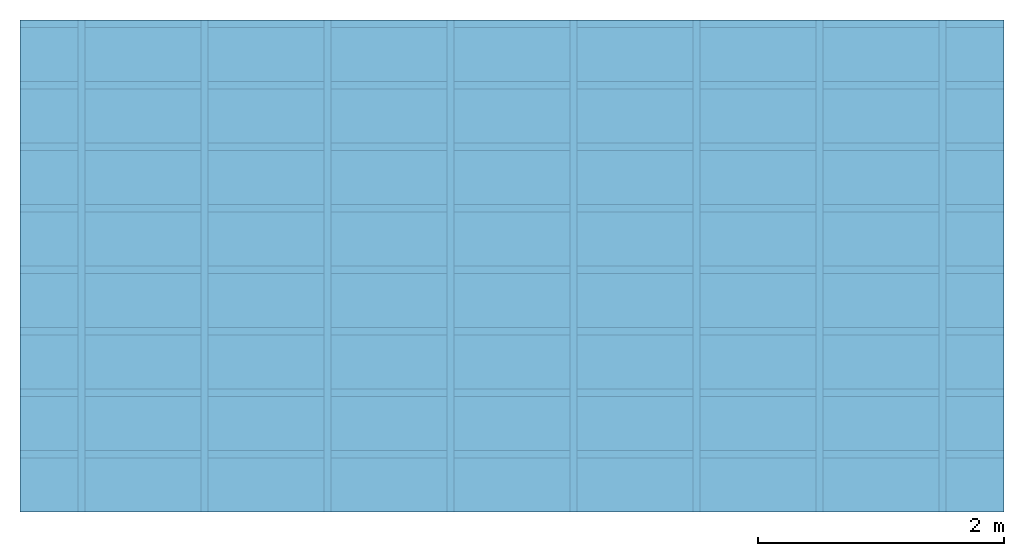
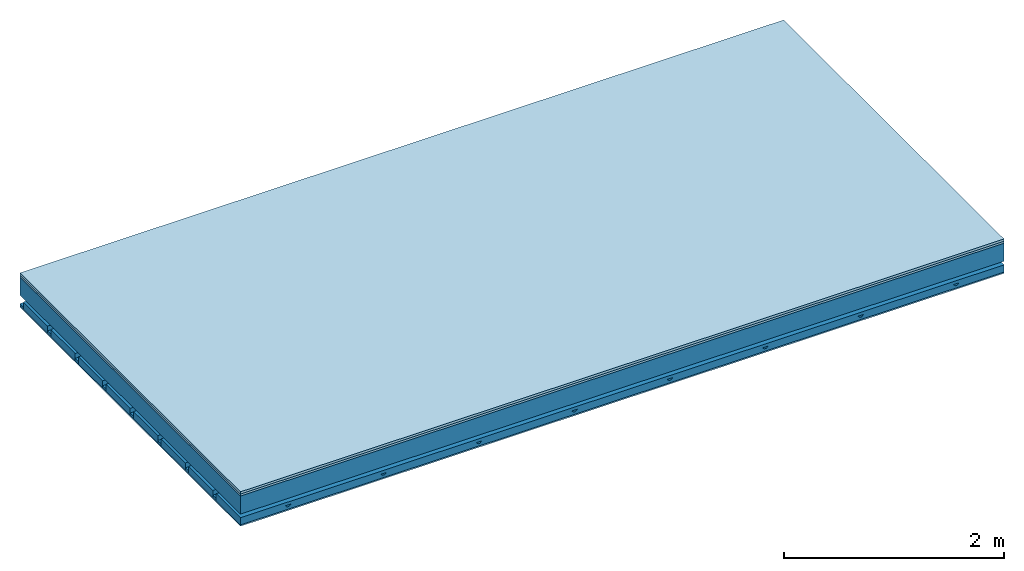
# One storey: 4 members, 3 plates, 1 element without a shape of its own.
"""IFC4 building model written with IfcOpenShell, lengths in metres."""

from ifc_helpers import new_model, si_unit, derived_unit, direction, frame, frame_2d, origin, origin_with_axes, place, context, project, spatial, polyline, rectangle, outline, extrude, material, layer, layer_set, type_object, element, aggregate, save


model = new_model("IFC4")

# Units and contexts
plan_context = context("Plan", 3, precision=1e-05, world=origin(), true_north=direction((0.0, 1.0)))
model_context = context("Model", 3, precision=1e-05, world=origin(), true_north=direction((0.0, 1.0)))
ifc_project = project(units=[si_unit("LENGTHUNIT", "METRE"), derived_unit("SOUNDPRESSUREUNIT", [(si_unit("PRESSUREUNIT", "PASCAL", prefix="MICRO"), 0)]), si_unit("ENERGYUNIT", "JOULE", prefix="MEGA"), si_unit("MASSUNIT", "GRAM", prefix="KILO"), derived_unit("THERMALTRANSMITTANCEUNIT", [(si_unit("POWERUNIT", "WATT"), 1), (si_unit("AREAUNIT", "SQUARE_METRE"), -1), (si_unit("THERMODYNAMICTEMPERATUREUNIT", "KELVIN"), -1)]), derived_unit("AREADENSITYUNIT", [(si_unit("MASSUNIT", "GRAM", prefix="KILO"), 1), (si_unit("AREAUNIT", "SQUARE_METRE"), -1)]), derived_unit("USERDEFINED", [(si_unit("ENERGYUNIT", "JOULE", prefix="MEGA"), 1), (si_unit("AREAUNIT", "SQUARE_METRE"), -1)])], contexts=[plan_context, model_context])

# Site, building, storey
site = spatial("IfcSite", under=ifc_project)
building_placement = place(None, origin())
building = spatial("IfcBuilding", under=site, at=building_placement)
storey_placement = place(building_placement, origin())
storey = spatial("IfcBuildingStorey", under=building, at=storey_placement)

# Slab, members, plates
ifc_material_1 = material(Name="Floor heating system Therm38 longitudinal", Category="03.007")
ifc_layer_1 = layer(ifc_material_1, 0.025, Name="On-material")
ifc_material_2 = material(Category="10.009")
ifc_layer_2 = layer(ifc_material_2, 0.022, Name="Impact sound insulation")
ifc_layer_3 = layer(None, 0.2, Name="Supporting structure")
ifc_material_3 = material(Name="no composite action")
ifc_layer_4 = layer(ifc_material_3, 0.0, Name="Bond")
ifc_layer_5 = layer(None, 0.093, Name="Coupling")
ifc_layer_6 = layer(None, 0.027, Name="Battens / profiles")
ifc_material_4 = material(Name="Plasterboard type A", Category="03.008")
ifc_layer_7 = layer(ifc_material_4, 0.015, Name="Ceiling covering 1st layer")
ifc_material_5 = material(Name="joints", Category="04.017")
ifc_layer_8 = layer(ifc_material_5, 0.0, Name="Surface / treatment")
ifc_layer_set = layer_set([ifc_layer_1, ifc_layer_2, ifc_layer_3, ifc_layer_4, ifc_layer_5, ifc_layer_6, ifc_layer_7, ifc_layer_8])
slab_type = type_object("IfcSlabType", Name="A0906", PredefinedType="NOTDEFINED", material=ifc_layer_set)
slab_placement = place(None, frame((0.0, 0.0, 0.0), z_axis=(0.0, 0.0, -1.0), x_axis=(1.0, 0.0, 0.0)))
slab = element("IfcSlab", 1, at=slab_placement, inside=storey, type_object=slab_type, material=ifc_layer_set, Name="Slab #1")
ifc_material_6 = material()
member_1_placement = place(slab_placement, origin())
member_1 = element("IfcMember", 2, at=member_1_placement, material=ifc_material_6, Name="Supporting structure", context=plan_context, shape_type="SweptSolid", body=[
    extrude(rectangle(XDim=1.0, YDim=0.2, at=frame_2d((0.5, 0.1), x_axis=(1.0, 0.0))), frame((0.0, 4.0, 0.047), z_axis=(0.0, -1.0, 0.0), x_axis=(1.0, 0.0, 0.0)), (0.0, 0.0, 1.0), 4.0),
    extrude(rectangle(XDim=1.0, YDim=0.2, at=frame_2d((0.5, 0.1), x_axis=(1.0, 0.0))), frame((1.0, 4.0, 0.047), z_axis=(0.0, -1.0, 0.0), x_axis=(1.0, 0.0, 0.0)), (0.0, 0.0, 1.0), 4.0),
    extrude(rectangle(XDim=1.0, YDim=0.2, at=frame_2d((0.5, 0.1), x_axis=(1.0, 0.0))), frame((2.0, 4.0, 0.047), z_axis=(0.0, -1.0, 0.0), x_axis=(1.0, 0.0, 0.0)), (0.0, 0.0, 1.0), 4.0),
    extrude(rectangle(XDim=1.0, YDim=0.2, at=frame_2d((0.5, 0.1), x_axis=(1.0, 0.0))), frame((3.0, 4.0, 0.047), z_axis=(0.0, -1.0, 0.0), x_axis=(1.0, 0.0, 0.0)), (0.0, 0.0, 1.0), 4.0),
    extrude(rectangle(XDim=1.0, YDim=0.2, at=frame_2d((0.5, 0.1), x_axis=(1.0, 0.0))), frame((4.0, 4.0, 0.047), z_axis=(0.0, -1.0, 0.0), x_axis=(1.0, 0.0, 0.0)), (0.0, 0.0, 1.0), 4.0),
    extrude(rectangle(XDim=1.0, YDim=0.2, at=frame_2d((0.5, 0.1), x_axis=(1.0, 0.0))), frame((5.0, 4.0, 0.047), z_axis=(0.0, -1.0, 0.0), x_axis=(1.0, 0.0, 0.0)), (0.0, 0.0, 1.0), 4.0),
    extrude(rectangle(XDim=1.0, YDim=0.2, at=frame_2d((0.5, 0.1), x_axis=(1.0, 0.0))), frame((6.0, 4.0, 0.047), z_axis=(0.0, -1.0, 0.0), x_axis=(1.0, 0.0, 0.0)), (0.0, 0.0, 1.0), 4.0),
    extrude(rectangle(XDim=1.0, YDim=0.2, at=frame_2d((0.5, 0.1), x_axis=(1.0, 0.0))), frame((7.0, 4.0, 0.047), z_axis=(0.0, -1.0, 0.0), x_axis=(1.0, 0.0, 0.0)), (0.0, 0.0, 1.0), 4.0),
])
ifc_material_7 = material()
member_2_placement = place(slab_placement, origin())
member_2 = element("IfcMember", 3, at=member_2_placement, material=ifc_material_7, Name="Coupling", context=plan_context, shape_type="SweptSolid", body=[
    extrude(outline(polyline([(0.0, 0.0), (0.06, 0.0), (0.04, 0.02), (0.02, 0.02), (0.0, 0.0)])), frame((0.47, 4.0, 0.32), z_axis=(0.0, -1.0, 0.0), x_axis=(1.0, 0.0, 0.0)), (0.0, 0.0, 1.0), 4.0),
    extrude(outline(polyline([(0.0, 0.0), (0.06, 0.0), (0.04, 0.02), (0.02, 0.02), (0.0, 0.0)])), frame((1.47, 4.0, 0.32), z_axis=(0.0, -1.0, 0.0), x_axis=(1.0, 0.0, 0.0)), (0.0, 0.0, 1.0), 4.0),
    extrude(outline(polyline([(0.0, 0.0), (0.06, 0.0), (0.04, 0.02), (0.02, 0.02), (0.0, 0.0)])), frame((2.47, 4.0, 0.32), z_axis=(0.0, -1.0, 0.0), x_axis=(1.0, 0.0, 0.0)), (0.0, 0.0, 1.0), 4.0),
    extrude(outline(polyline([(0.0, 0.0), (0.06, 0.0), (0.04, 0.02), (0.02, 0.02), (0.0, 0.0)])), frame((3.47, 4.0, 0.32), z_axis=(0.0, -1.0, 0.0), x_axis=(1.0, 0.0, 0.0)), (0.0, 0.0, 1.0), 4.0),
    extrude(outline(polyline([(0.0, 0.0), (0.06, 0.0), (0.04, 0.02), (0.02, 0.02), (0.0, 0.0)])), frame((4.47, 4.0, 0.32), z_axis=(0.0, -1.0, 0.0), x_axis=(1.0, 0.0, 0.0)), (0.0, 0.0, 1.0), 4.0),
    extrude(outline(polyline([(0.0, 0.0), (0.06, 0.0), (0.04, 0.02), (0.02, 0.02), (0.0, 0.0)])), frame((5.47, 4.0, 0.32), z_axis=(0.0, -1.0, 0.0), x_axis=(1.0, 0.0, 0.0)), (0.0, 0.0, 1.0), 4.0),
    extrude(outline(polyline([(0.0, 0.0), (0.06, 0.0), (0.04, 0.02), (0.02, 0.02), (0.0, 0.0)])), frame((6.47, 4.0, 0.32), z_axis=(0.0, -1.0, 0.0), x_axis=(1.0, 0.0, 0.0)), (0.0, 0.0, 1.0), 4.0),
    extrude(outline(polyline([(0.0, 0.0), (0.06, 0.0), (0.04, 0.02), (0.02, 0.02), (0.0, 0.0)])), frame((7.47, 4.0, 0.32), z_axis=(0.0, -1.0, 0.0), x_axis=(1.0, 0.0, 0.0)), (0.0, 0.0, 1.0), 4.0),
])
ifc_material_8 = material()
member_3_placement = place(slab_placement, origin())
member_3 = element("IfcMember", 4, at=member_3_placement, material=ifc_material_8, Name="Battens / profiles", context=plan_context, shape_type="SweptSolid", body=[
    extrude(rectangle(XDim=0.06, YDim=0.027, at=frame_2d((0.03, 0.0135), x_axis=(1.0, 0.0))), frame((0.0, 0.0, 0.34), z_axis=(1.0, 0.0, 0.0), x_axis=(0.0, 1.0, 0.0)), (0.0, 0.0, 1.0), 8.0),
    extrude(rectangle(XDim=0.06, YDim=0.027, at=frame_2d((0.03, 0.0135), x_axis=(1.0, 0.0))), frame((0.0, 0.5, 0.34), z_axis=(1.0, 0.0, 0.0), x_axis=(0.0, 1.0, 0.0)), (0.0, 0.0, 1.0), 8.0),
    extrude(rectangle(XDim=0.06, YDim=0.027, at=frame_2d((0.03, 0.0135), x_axis=(1.0, 0.0))), frame((0.0, 1.0, 0.34), z_axis=(1.0, 0.0, 0.0), x_axis=(0.0, 1.0, 0.0)), (0.0, 0.0, 1.0), 8.0),
    extrude(rectangle(XDim=0.06, YDim=0.027, at=frame_2d((0.03, 0.0135), x_axis=(1.0, 0.0))), frame((0.0, 1.5, 0.34), z_axis=(1.0, 0.0, 0.0), x_axis=(0.0, 1.0, 0.0)), (0.0, 0.0, 1.0), 8.0),
    extrude(rectangle(XDim=0.06, YDim=0.027, at=frame_2d((0.03, 0.0135), x_axis=(1.0, 0.0))), frame((0.0, 2.0, 0.34), z_axis=(1.0, 0.0, 0.0), x_axis=(0.0, 1.0, 0.0)), (0.0, 0.0, 1.0), 8.0),
    extrude(rectangle(XDim=0.06, YDim=0.027, at=frame_2d((0.03, 0.0135), x_axis=(1.0, 0.0))), frame((0.0, 2.5, 0.34), z_axis=(1.0, 0.0, 0.0), x_axis=(0.0, 1.0, 0.0)), (0.0, 0.0, 1.0), 8.0),
    extrude(rectangle(XDim=0.06, YDim=0.027, at=frame_2d((0.03, 0.0135), x_axis=(1.0, 0.0))), frame((0.0, 3.0, 0.34), z_axis=(1.0, 0.0, 0.0), x_axis=(0.0, 1.0, 0.0)), (0.0, 0.0, 1.0), 8.0),
    extrude(rectangle(XDim=0.06, YDim=0.027, at=frame_2d((0.03, 0.0135), x_axis=(1.0, 0.0))), frame((0.0, 3.5, 0.34), z_axis=(1.0, 0.0, 0.0), x_axis=(0.0, 1.0, 0.0)), (0.0, 0.0, 1.0), 8.0),
])
ifc_material_9 = material()
member_4_placement = place(slab_placement, origin())
member_4 = element("IfcMember", 5, at=member_4_placement, material=ifc_material_9, Name="Cavity", context=plan_context, shape_type="SweptSolid", body=[
    extrude(rectangle(XDim=0.44, YDim=0.08, at=frame_2d((0.22, 0.04), x_axis=(1.0, 0.0))), frame((0.0, 0.06, 0.287), z_axis=(1.0, 0.0, 0.0), x_axis=(0.0, 1.0, 0.0)), (0.0, 0.0, 1.0), 8.0),
    extrude(rectangle(XDim=0.44, YDim=0.08, at=frame_2d((0.22, 0.04), x_axis=(1.0, 0.0))), frame((0.0, 0.56, 0.287), z_axis=(1.0, 0.0, 0.0), x_axis=(0.0, 1.0, 0.0)), (0.0, 0.0, 1.0), 8.0),
    extrude(rectangle(XDim=0.44, YDim=0.08, at=frame_2d((0.22, 0.04), x_axis=(1.0, 0.0))), frame((0.0, 1.06, 0.287), z_axis=(1.0, 0.0, 0.0), x_axis=(0.0, 1.0, 0.0)), (0.0, 0.0, 1.0), 8.0),
    extrude(rectangle(XDim=0.44, YDim=0.08, at=frame_2d((0.22, 0.04), x_axis=(1.0, 0.0))), frame((0.0, 1.56, 0.287), z_axis=(1.0, 0.0, 0.0), x_axis=(0.0, 1.0, 0.0)), (0.0, 0.0, 1.0), 8.0),
    extrude(rectangle(XDim=0.44, YDim=0.08, at=frame_2d((0.22, 0.04), x_axis=(1.0, 0.0))), frame((0.0, 2.06, 0.287), z_axis=(1.0, 0.0, 0.0), x_axis=(0.0, 1.0, 0.0)), (0.0, 0.0, 1.0), 8.0),
    extrude(rectangle(XDim=0.44, YDim=0.08, at=frame_2d((0.22, 0.04), x_axis=(1.0, 0.0))), frame((0.0, 2.56, 0.287), z_axis=(1.0, 0.0, 0.0), x_axis=(0.0, 1.0, 0.0)), (0.0, 0.0, 1.0), 8.0),
    extrude(rectangle(XDim=0.44, YDim=0.08, at=frame_2d((0.22, 0.04), x_axis=(1.0, 0.0))), frame((0.0, 3.06, 0.287), z_axis=(1.0, 0.0, 0.0), x_axis=(0.0, 1.0, 0.0)), (0.0, 0.0, 1.0), 8.0),
    extrude(rectangle(XDim=0.44, YDim=0.08, at=frame_2d((0.22, 0.04), x_axis=(1.0, 0.0))), frame((0.0, 3.56, 0.287), z_axis=(1.0, 0.0, 0.0), x_axis=(0.0, 1.0, 0.0)), (0.0, 0.0, 1.0), 8.0),
])
plate_1_placement = place(slab_placement, origin())
plate_1 = element("IfcPlate", 6, at=plate_1_placement, material=ifc_material_1, Name="On-material", context=plan_context, shape_type="SweptSolid", body=[
    extrude(rectangle(XDim=8.0, YDim=4.0, at=frame_2d((4.0, 2.0), x_axis=(1.0, 0.0))), origin_with_axes(), (0.0, 0.0, 1.0), 0.025),
])
plate_2_placement = place(slab_placement, origin())
plate_2 = element("IfcPlate", 7, at=plate_2_placement, material=ifc_material_2, Name="Impact sound insulation", context=plan_context, shape_type="SweptSolid", body=[
    extrude(rectangle(XDim=8.0, YDim=4.0, at=frame_2d((4.0, 2.0), x_axis=(1.0, 0.0))), frame((0.0, 0.0, 0.025), z_axis=(0.0, 0.0, 1.0), x_axis=(1.0, 0.0, 0.0)), (0.0, 0.0, 1.0), 0.022),
])
plate_3_placement = place(slab_placement, origin())
plate_3 = element("IfcPlate", 8, at=plate_3_placement, material=ifc_material_4, Name="Ceiling covering 1st layer", context=plan_context, shape_type="SweptSolid", body=[
    extrude(rectangle(XDim=8.0, YDim=4.0, at=frame_2d((4.0, 2.0), x_axis=(1.0, 0.0))), frame((0.0, 0.0, 0.367), z_axis=(0.0, 0.0, 1.0), x_axis=(1.0, 0.0, 0.0)), (0.0, 0.0, 1.0), 0.015),
])
aggregate(slab, [plate_1, plate_2, member_1, member_2, member_3, member_4, plate_3])

save(model, "model.ifc")
